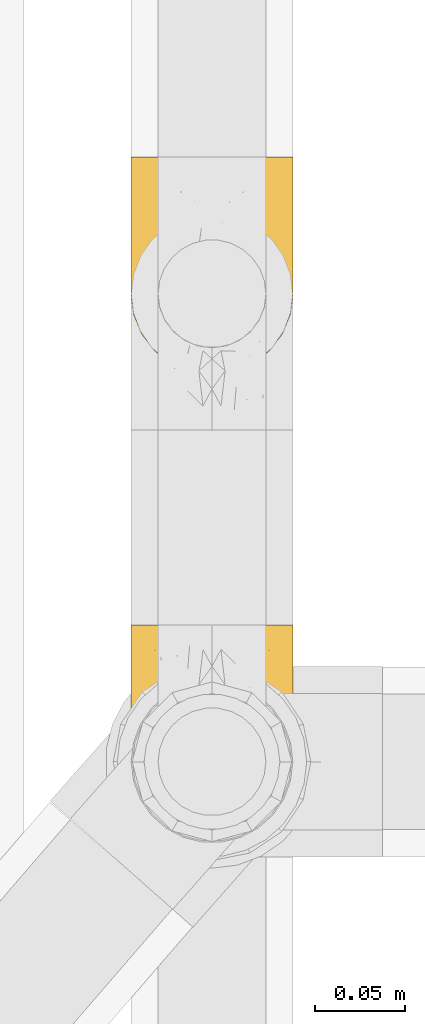
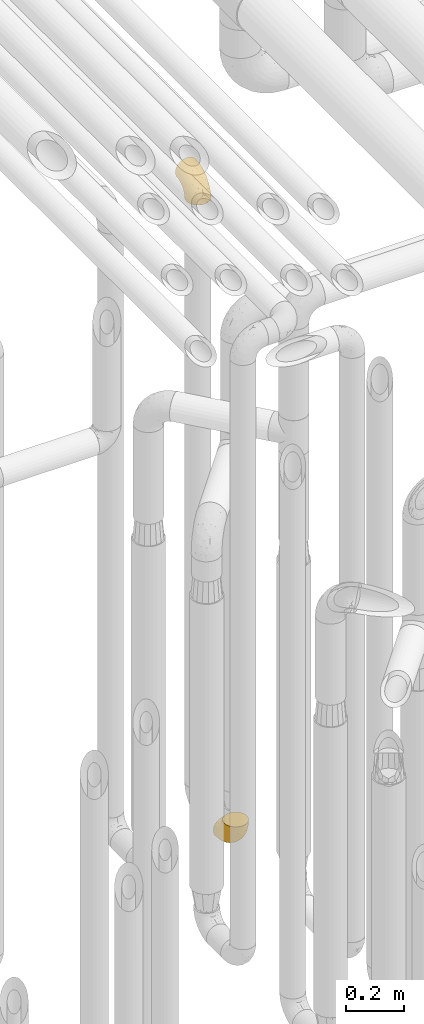
# One storey, part 231 of 827: 2 coverings.
"""IFC2X3 building model written with IfcOpenShell, lengths in millimetres."""

from ifc_helpers import new_model, entity, si_unit, converted_unit, derived_unit, direction, frame, origin, place, context, subcontext, project, spatial, faceted_brep, element, save


model = new_model("IFC2X3")

# Units and contexts
model_context = context("Model", 3, precision=0.01, world=origin(), true_north=direction((6.12303176911189e-17, 1.0)))
body_context = subcontext(model_context, "Body", "Model", "MODEL_VIEW")
ifc_project = project(units=[si_unit("LENGTHUNIT", "METRE", prefix="MILLI"), si_unit("AREAUNIT", "SQUARE_METRE"), si_unit("VOLUMEUNIT", "CUBIC_METRE"), converted_unit("PLANEANGLEUNIT", "DEGREE", entity("IfcRatioMeasure", 0.0174532925199433), si_unit("PLANEANGLEUNIT", "RADIAN"), dimensions=[0, 0, 0, 0, 0, 0, 0]), si_unit("MASSUNIT", "GRAM", prefix="KILO"), derived_unit("MASSDENSITYUNIT", [(si_unit("MASSUNIT", "GRAM", prefix="KILO"), 1), (si_unit("LENGTHUNIT", "METRE"), -3)]), derived_unit("MOMENTOFINERTIAUNIT", [(si_unit("LENGTHUNIT", "METRE"), 4)]), si_unit("TIMEUNIT", "SECOND"), si_unit("FREQUENCYUNIT", "HERTZ"), si_unit("THERMODYNAMICTEMPERATUREUNIT", "DEGREE_CELSIUS"), derived_unit("THERMALTRANSMITTANCEUNIT", [(si_unit("MASSUNIT", "GRAM", prefix="KILO"), 1), (si_unit("THERMODYNAMICTEMPERATUREUNIT", "KELVIN"), -1), (si_unit("TIMEUNIT", "SECOND"), -3)]), derived_unit("VOLUMETRICFLOWRATEUNIT", [(si_unit("LENGTHUNIT", "METRE"), 3), (si_unit("TIMEUNIT", "SECOND"), -1)]), derived_unit("MASSFLOWRATEUNIT", [(si_unit("MASSUNIT", "GRAM", prefix="KILO"), 1), (si_unit("TIMEUNIT", "SECOND"), -1)]), derived_unit("ROTATIONALFREQUENCYUNIT", [(si_unit("TIMEUNIT", "SECOND"), -1)]), si_unit("ELECTRICCURRENTUNIT", "AMPERE"), si_unit("ELECTRICVOLTAGEUNIT", "VOLT"), si_unit("POWERUNIT", "WATT"), si_unit("FORCEUNIT", "NEWTON", prefix="KILO"), si_unit("ILLUMINANCEUNIT", "LUX"), si_unit("LUMINOUSFLUXUNIT", "LUMEN"), si_unit("LUMINOUSINTENSITYUNIT", "CANDELA"), derived_unit("USERDEFINED", [(si_unit("MASSUNIT", "GRAM", prefix="KILO"), -1), (si_unit("LENGTHUNIT", "METRE"), -2), (si_unit("TIMEUNIT", "SECOND"), 3), (si_unit("LUMINOUSFLUXUNIT", "LUMEN"), 1)]), derived_unit("LINEARVELOCITYUNIT", [(si_unit("LENGTHUNIT", "METRE"), 1), (si_unit("TIMEUNIT", "SECOND"), -1)]), si_unit("PRESSUREUNIT", "PASCAL"), derived_unit("USERDEFINED", [(si_unit("LENGTHUNIT", "METRE"), -2), (si_unit("MASSUNIT", "GRAM", prefix="KILO"), 1), (si_unit("TIMEUNIT", "SECOND"), -2)]), derived_unit("LINEARFORCEUNIT", [(si_unit("MASSUNIT", "GRAM", prefix="KILO"), 1), (si_unit("LENGTHUNIT", "METRE"), 1), (si_unit("TIMEUNIT", "SECOND"), -2), (si_unit("LENGTHUNIT", "METRE"), -1)]), derived_unit("PLANARFORCEUNIT", [(si_unit("MASSUNIT", "GRAM", prefix="KILO"), 1), (si_unit("LENGTHUNIT", "METRE"), 1), (si_unit("TIMEUNIT", "SECOND"), -2), (si_unit("LENGTHUNIT", "METRE"), -2)])], contexts=[model_context])

# Site, building, storey
site_placement = place(None, origin())
site = spatial("IfcSite", under=ifc_project, at=site_placement, CompositionType="ELEMENT")
building_placement = place(site_placement, origin())
building = spatial("IfcBuilding", under=site, at=building_placement, CompositionType="ELEMENT")
storey_placement = place(building_placement, frame((0.0, 0.0, 28200.0)))
storey = spatial("IfcBuildingStorey", under=building, at=storey_placement, Name="08", CompositionType="ELEMENT", Elevation=28200.0)

# Coverings
covering_1_placement = place(storey_placement, frame((36928.29, 12932.9, 353.25)))
element("IfcCovering", 1, at=covering_1_placement, inside=storey, Name=":ADSK_", ObjectType=":ADSK_", PredefinedType="INSULATION", context=body_context, shape_type="Brep", body=[
    faceted_brep([(2.73, 36.69, 122.75), (6.07, 27.15, 122.75), (11.45, 18.59, 122.75), (18.6, 11.44, 122.75), (27.16, 6.06, 122.75), (36.7, 2.73, 122.75), (46.75, 1.6, 122.75), (56.8, 2.73, 122.75), (66.34, 6.07, 122.75), (74.9, 11.45, 122.75), (82.05, 18.6, 122.75), (87.43, 27.16, 122.75), (90.76, 36.7, 122.75), (91.9, 46.75, 122.75), (90.76, 56.8, 122.75), (87.42, 66.34, 122.75), (82.04, 74.9, 122.75), (74.89, 82.05, 122.75), (66.33, 87.43, 122.75), (56.79, 90.76, 122.75), (46.75, 91.9, 122.75), (36.69, 90.76, 122.75), (27.15, 87.42, 122.75), (18.59, 82.04, 122.75), (11.44, 74.89, 122.75), (6.06, 66.33, 122.75), (2.73, 56.79, 122.75), (1.6, 46.75, 122.75), (58.43, 122.75, 90.36), (69.32, 122.75, 85.85), (78.67, 122.75, 78.67), (85.85, 122.75, 69.32), (90.36, 122.75, 58.43), (91.9, 122.75, 46.75), (90.36, 122.75, 35.06), (85.85, 122.75, 24.17), (78.67, 122.75, 14.82), (69.32, 122.75, 7.64), (58.43, 122.75, 3.13), (46.75, 122.75, 1.6), (35.06, 122.75, 3.13), (24.17, 122.75, 7.64), (14.82, 122.75, 14.82), (7.64, 122.75, 24.17), (3.13, 122.75, 35.06), (1.6, 122.75, 46.75), (3.13, 122.75, 58.43), (7.64, 122.75, 69.32), (14.82, 122.75, 78.67), (24.17, 122.75, 85.85), (35.06, 122.75, 90.36), (46.75, 122.75, 91.9), (46.75, 24.73, 51.54), (38.29, 29.08, 47.17), (46.75, 38.13, 38.13), (46.75, 85.31, 7.52), (38.96, 93.59, 5.85), (46.75, 100.54, 5.11), (33.86, 63.54, 19.2), (31.42, 38.98, 38.98), (21.63, 50.71, 35.02), (30.84, 93.33, 8.21), (22.16, 75.2, 19.28), (20.56, 100.46, 12.19), (2.29, 41.6, 101.39), (7.18, 80.86, 34.43), (12.6, 94.87, 20.95), (14.0, 67.96, 30.74), (2.81, 52.16, 72.93), (6.65, 52.1, 56.64), (6.11, 36.74, 80.81), (16.62, 17.11, 93.43), (9.76, 23.24, 100.76), (12.46, 29.18, 74.27), (1.6, 52.53, 93.66), (1.6, 60.77, 81.33), (1.6, 69.01, 69.01), (2.46, 100.68, 40.87), (5.91, 103.79, 29.38), (36.97, 16.37, 67.05), (46.75, 7.52, 85.31), (33.09, 7.31, 93.68), (1.6, 93.66, 52.53), (1.6, 102.83, 50.71), (1.6, 112.01, 48.88), (25.62, 18.17, 72.77), (3.14, 71.97, 51.21), (23.92, 9.83, 101.18), (46.75, 5.11, 100.54), (13.58, 45.97, 48.74), (1.6, 48.88, 112.01), (1.6, 50.71, 102.83), (18.5, 22.83, 73.88), (46.75, 51.54, 24.73), (1.6, 81.33, 60.77), (4.96, 31.74, 103.08), (20.84, 32.48, 54.8), (46.75, 68.42, 16.13), (30.52, 25.33, 55.92), (46.75, 16.13, 68.42), (27.29, 92.29, 104.98), (36.89, 94.12, 108.58), (33.6, 100.97, 98.21), (2.54, 95.91, 61.56), (3.27, 107.9, 60.69), (16.85, 87.24, 100.0), (21.91, 95.46, 95.88), (13.5, 90.41, 90.81), (3.96, 74.17, 84.88), (3.52, 83.77, 73.29), (12.17, 76.72, 113.4), (18.93, 84.44, 109.8), (9.34, 76.42, 102.13), (3.12, 90.07, 67.29), (5.67, 99.69, 70.34), (2.51, 61.74, 95.15), (2.53, 58.16, 105.49), (8.35, 112.6, 71.5), (35.39, 110.45, 92.87), (46.75, 107.32, 96.03), (15.1, 108.48, 81.34), (5.27, 66.63, 107.44), (27.43, 115.23, 88.36), (24.89, 105.79, 90.43), (29.71, 89.6, 114.37), (5.07, 69.39, 98.41), (2.88, 66.99, 88.73), (9.69, 102.31, 76.89), (15.51, 99.54, 86.08), (2.27, 55.27, 112.64), (10.03, 82.03, 94.21), (46.75, 94.71, 112.22), (46.75, 96.03, 107.32), (8.83, 94.11, 79.95), (7.16, 84.21, 84.51), (46.75, 101.67, 101.67), (46.75, 112.22, 94.71), (78.39, 108.48, 81.34), (83.8, 102.31, 76.89), (77.97, 99.54, 86.08), (84.66, 94.11, 79.96), (58.1, 110.46, 92.87), (81.31, 76.74, 113.41), (91.9, 50.71, 102.83), (90.96, 58.17, 105.5), (91.22, 55.27, 112.64), (56.59, 94.12, 108.58), (66.18, 92.3, 104.98), (59.87, 100.98, 98.2), (88.42, 69.41, 98.4), (84.13, 76.44, 102.13), (88.22, 66.65, 107.44), (66.06, 115.24, 88.36), (91.9, 102.83, 50.71), (91.9, 112.01, 48.88), (83.44, 82.05, 94.22), (76.62, 87.25, 100.01), (85.14, 112.6, 71.5), (90.22, 107.9, 60.69), (91.9, 93.66, 52.53), (71.55, 95.48, 95.89), (63.77, 89.6, 114.37), (91.9, 60.77, 81.33), (91.9, 69.01, 69.01), (89.53, 74.17, 84.88), (91.9, 48.88, 112.01), (74.55, 84.45, 109.8), (90.95, 95.91, 61.56), (90.37, 90.07, 67.29), (91.9, 81.33, 60.77), (90.98, 61.75, 95.14), (89.97, 83.77, 73.29), (86.32, 84.21, 84.53), (91.9, 52.53, 93.66), (79.97, 90.42, 90.82), (90.61, 67.0, 88.73), (87.82, 99.69, 70.34), (68.6, 105.8, 90.43), (80.89, 94.87, 20.95), (86.31, 80.86, 34.43), (79.49, 67.95, 30.74), (71.33, 75.17, 19.29), (71.88, 50.65, 35.07), (90.35, 71.97, 51.21), (86.85, 52.08, 56.67), (72.67, 32.46, 54.85), (62.08, 38.98, 38.98), (87.58, 103.79, 29.38), (91.03, 100.68, 40.87), (59.62, 63.54, 19.2), (62.65, 93.32, 8.21), (54.53, 93.59, 5.85), (72.93, 100.44, 12.19), (90.68, 52.17, 72.93), (87.39, 36.75, 80.83), (91.2, 41.61, 101.39), (60.41, 7.31, 93.69), (76.88, 17.12, 93.43), (56.53, 16.37, 67.04), (83.74, 23.26, 100.76), (67.88, 18.17, 72.78), (62.99, 25.33, 55.93), (69.58, 9.84, 101.18), (81.04, 29.19, 74.27), (75.0, 22.84, 73.89), (88.53, 31.75, 103.09), (79.93, 45.96, 48.78), (55.21, 29.07, 47.19)], [[[0, 1, 2, 3, 4, 5, 6, 7, 8, 9, 10, 11, 12, 13, 14, 15, 16, 17, 18, 19, 20, 21, 22, 23, 24, 25, 26, 27]], [[28, 29, 30, 31, 32, 33, 34, 35, 36, 37, 38, 39, 40, 41, 42, 43, 44, 45, 46, 47, 48, 49, 50, 51]], [[52, 53, 54]], [[55, 56, 57]], [[58, 59, 60]], [[61, 62, 63]], [[27, 64, 0]], [[65, 66, 67]], [[41, 40, 61]], [[68, 69, 70]], [[66, 43, 42]], [[63, 42, 41]], [[71, 72, 73]], [[72, 2, 1]], [[68, 74, 75, 76]], [[45, 44, 77]], [[43, 78, 44]], [[79, 80, 81]], [[77, 82, 83, 84, 45]], [[79, 81, 85]], [[71, 2, 72]], [[65, 86, 77]], [[4, 81, 5]], [[66, 65, 78]], [[4, 3, 87]], [[81, 88, 5]], [[63, 66, 42]], [[68, 70, 64]], [[67, 60, 89]], [[71, 3, 2]], [[64, 27, 90, 91, 74]], [[92, 71, 73]], [[40, 57, 56]], [[59, 93, 54]], [[86, 76, 94, 82]], [[1, 0, 95]], [[58, 62, 61]], [[60, 96, 89]], [[85, 81, 87]], [[56, 97, 58]], [[65, 67, 69]], [[87, 81, 4]], [[67, 89, 69]], [[61, 63, 41]], [[95, 72, 1]], [[73, 72, 70]], [[69, 73, 70]], [[73, 89, 96]], [[3, 71, 87]], [[85, 87, 71]], [[58, 61, 56]], [[59, 58, 93]], [[76, 86, 68]], [[69, 89, 73]], [[68, 86, 69]], [[65, 69, 86]], [[68, 64, 74]], [[95, 64, 70]], [[98, 79, 85]], [[79, 52, 99, 80]], [[66, 62, 67]], [[62, 58, 60]], [[62, 60, 67]], [[59, 98, 96]], [[59, 96, 60]], [[96, 85, 92]], [[88, 81, 80]], [[88, 6, 5]], [[66, 63, 62]], [[64, 95, 0]], [[72, 95, 70]], [[77, 44, 78]], [[86, 82, 77]], [[40, 39, 57]], [[96, 98, 85]], [[40, 56, 61]], [[66, 78, 43]], [[77, 78, 65]], [[79, 98, 53]], [[96, 92, 73]], [[85, 71, 92]], [[97, 56, 55]], [[97, 93, 58]], [[53, 98, 59]], [[54, 53, 59]], [[79, 53, 52]], [[100, 101, 102]], [[46, 45, 84, 83]], [[103, 104, 82]], [[82, 104, 83]], [[105, 106, 107]], [[108, 109, 76]], [[110, 111, 112]], [[103, 113, 114]], [[115, 74, 116]], [[48, 47, 117]], [[118, 102, 119]], [[49, 48, 120]], [[74, 91, 116]], [[116, 121, 115]], [[49, 122, 50]], [[123, 106, 102]], [[124, 111, 22]], [[125, 126, 115]], [[23, 22, 111]], [[24, 110, 121]], [[120, 127, 128]], [[90, 26, 129]], [[27, 26, 90]], [[121, 125, 115]], [[24, 121, 25]], [[130, 105, 107]], [[129, 25, 116]], [[21, 20, 131]], [[120, 123, 122]], [[112, 105, 130]], [[50, 118, 51]], [[21, 124, 22]], [[101, 131, 132]], [[117, 120, 48]], [[24, 23, 110]], [[127, 114, 133]], [[75, 108, 76]], [[107, 134, 130]], [[133, 114, 113]], [[129, 116, 91]], [[25, 121, 116]], [[121, 112, 125]], [[75, 74, 115]], [[101, 135, 102]], [[131, 101, 21]], [[101, 100, 124]], [[128, 127, 133]], [[119, 136, 51, 118]], [[104, 47, 46]], [[83, 104, 46]], [[117, 104, 114]], [[101, 124, 21]], [[111, 124, 100]], [[102, 118, 123]], [[133, 134, 107]], [[111, 110, 23]], [[114, 104, 103]], [[94, 76, 109]], [[121, 110, 112]], [[122, 118, 50]], [[134, 109, 108]], [[133, 107, 128]], [[112, 108, 125]], [[126, 125, 108]], [[108, 75, 126]], [[75, 115, 126]], [[109, 134, 133]], [[130, 108, 112]], [[108, 130, 134]], [[105, 112, 111]], [[111, 100, 105]], [[106, 105, 100]], [[102, 106, 100]], [[128, 106, 123]], [[90, 129, 91]], [[25, 129, 26]], [[104, 117, 47]], [[117, 114, 127]], [[82, 94, 103]], [[113, 94, 109]], [[94, 113, 103]], [[133, 113, 109]], [[106, 128, 107]], [[123, 120, 128]], [[120, 122, 49]], [[118, 122, 123]], [[135, 101, 132]], [[135, 119, 102]], [[117, 127, 120]], [[30, 29, 137]], [[138, 139, 140]], [[51, 136, 119, 141]], [[142, 17, 16]], [[143, 144, 145]], [[146, 147, 148]], [[149, 150, 151]], [[152, 29, 28]], [[33, 32, 153, 154]], [[150, 155, 156]], [[157, 31, 30]], [[153, 158, 159]], [[29, 152, 137]], [[148, 141, 119]], [[156, 160, 147]], [[148, 135, 146]], [[137, 138, 157]], [[19, 161, 146]], [[162, 163, 164]], [[14, 13, 165]], [[153, 32, 158]], [[147, 161, 166]], [[18, 17, 166]], [[167, 168, 169]], [[166, 150, 156]], [[151, 150, 142]], [[151, 170, 149]], [[151, 16, 15]], [[171, 140, 172]], [[165, 143, 145]], [[173, 170, 144]], [[142, 166, 17]], [[19, 131, 20]], [[144, 170, 151]], [[18, 161, 19]], [[173, 144, 143]], [[140, 139, 174]], [[171, 164, 163]], [[164, 172, 155]], [[151, 15, 144]], [[145, 15, 14]], [[173, 162, 170]], [[149, 175, 164]], [[19, 146, 131]], [[132, 131, 146]], [[160, 148, 147]], [[159, 158, 167]], [[135, 132, 146]], [[158, 32, 31]], [[157, 158, 31]], [[167, 158, 176]], [[166, 161, 18]], [[146, 161, 147]], [[148, 177, 141]], [[171, 168, 140]], [[171, 163, 169]], [[151, 142, 16]], [[166, 142, 150]], [[152, 141, 177]], [[51, 141, 28]], [[138, 140, 176]], [[172, 140, 174]], [[175, 149, 170]], [[164, 150, 149]], [[170, 162, 175]], [[162, 164, 175]], [[155, 172, 174]], [[171, 172, 164]], [[155, 174, 156]], [[164, 155, 150]], [[160, 156, 174]], [[147, 166, 156]], [[139, 160, 174]], [[148, 160, 177]], [[15, 145, 144]], [[165, 145, 14]], [[137, 157, 30]], [[158, 157, 176]], [[168, 167, 176]], [[169, 159, 167]], [[140, 168, 176]], [[169, 168, 171]], [[137, 177, 139]], [[160, 139, 177]], [[141, 152, 28]], [[137, 152, 177]], [[148, 119, 135]], [[157, 138, 176]], [[139, 138, 137]], [[178, 179, 180]], [[181, 180, 182]], [[179, 183, 184]], [[185, 186, 182]], [[187, 188, 179]], [[188, 33, 154, 153, 159]], [[181, 189, 190]], [[35, 34, 187]], [[191, 38, 190]], [[192, 178, 181]], [[179, 184, 180]], [[192, 190, 37]], [[37, 190, 38]], [[36, 35, 178]], [[54, 93, 186]], [[35, 187, 178]], [[193, 194, 184]], [[195, 173, 143, 165, 13]], [[195, 193, 173]], [[193, 163, 162, 173]], [[13, 12, 195]], [[8, 7, 196]], [[9, 197, 10]], [[198, 80, 99, 52]], [[196, 7, 88]], [[197, 199, 10]], [[182, 189, 181]], [[200, 198, 201]], [[200, 196, 198]], [[9, 8, 202]], [[194, 199, 203]], [[192, 37, 36]], [[80, 196, 88]], [[183, 159, 169, 163]], [[188, 34, 33]], [[202, 200, 197]], [[185, 203, 204]], [[202, 8, 196]], [[10, 199, 11]], [[12, 11, 205]], [[38, 191, 57]], [[189, 97, 191]], [[203, 199, 197]], [[205, 199, 194]], [[204, 203, 197]], [[184, 203, 206]], [[200, 202, 196]], [[197, 9, 202]], [[207, 54, 186]], [[97, 55, 191]], [[194, 203, 184]], [[183, 163, 193]], [[184, 206, 180]], [[183, 193, 184]], [[205, 195, 12]], [[193, 195, 194]], [[80, 198, 196]], [[207, 186, 201]], [[182, 180, 206]], [[181, 178, 180]], [[185, 182, 206]], [[182, 186, 189]], [[203, 185, 206]], [[185, 200, 201]], [[7, 6, 88]], [[178, 192, 36]], [[190, 192, 181]], [[199, 205, 11]], [[195, 205, 194]], [[159, 183, 188]], [[179, 188, 183]], [[57, 191, 55]], [[57, 39, 38]], [[189, 191, 190]], [[188, 187, 34]], [[178, 187, 179]], [[186, 93, 189]], [[197, 200, 204]], [[185, 204, 200]], [[189, 93, 97]], [[207, 198, 52]], [[185, 201, 186]], [[198, 207, 201]], [[54, 207, 52]]]),
])
covering_2_placement = place(storey_placement, frame((36928.29, 13193.46, 2922.4)))
element("IfcCovering", 2, at=covering_2_placement, inside=storey, Name=":ADSK_", ObjectType=":ADSK_", PredefinedType="INSULATION", context=body_context, shape_type="Brep", body=[
    faceted_brep([(2.73, 122.75, 87.65), (6.07, 122.75, 97.19), (11.45, 122.75, 105.75), (18.6, 122.75, 112.9), (27.16, 122.75, 118.28), (36.7, 122.75, 121.61), (46.75, 122.75, 122.75), (56.8, 122.75, 121.61), (66.34, 122.75, 118.27), (74.9, 122.75, 112.89), (82.05, 122.75, 105.74), (87.43, 122.75, 97.18), (90.76, 122.75, 87.64), (91.9, 122.75, 77.6), (90.76, 122.75, 67.54), (87.42, 122.75, 58.0), (82.04, 122.75, 49.44), (74.89, 122.75, 42.29), (66.33, 122.75, 36.91), (56.79, 122.75, 33.58), (46.75, 122.75, 32.45), (36.69, 122.75, 33.58), (27.15, 122.75, 36.92), (18.59, 122.75, 42.3), (11.44, 122.75, 49.45), (6.06, 122.75, 58.01), (2.73, 122.75, 67.55), (1.6, 122.75, 77.6), (58.43, 90.36, 1.6), (69.32, 85.85, 1.6), (78.67, 78.67, 1.6), (85.85, 69.32, 1.6), (90.36, 58.43, 1.6), (91.9, 46.75, 1.6), (90.36, 35.06, 1.6), (85.85, 24.17, 1.6), (78.67, 14.82, 1.6), (69.32, 7.64, 1.6), (58.43, 3.13, 1.6), (46.75, 1.6, 1.6), (35.06, 3.13, 1.6), (24.17, 7.64, 1.6), (14.82, 14.82, 1.6), (7.64, 24.17, 1.6), (3.13, 35.06, 1.6), (1.6, 46.75, 1.6), (3.13, 58.43, 1.6), (7.64, 69.32, 1.6), (14.82, 78.67, 1.6), (24.17, 85.85, 1.6), (35.06, 90.36, 1.6), (46.75, 91.9, 1.6), (46.75, 51.54, 99.61), (38.29, 47.17, 95.26), (46.75, 38.13, 86.21), (46.75, 7.52, 39.03), (38.96, 5.85, 30.75), (46.75, 5.11, 23.8), (33.86, 19.2, 60.8), (31.42, 38.98, 85.37), (21.63, 35.02, 73.64), (30.84, 8.21, 31.01), (22.16, 19.28, 49.14), (20.56, 12.19, 23.88), (2.29, 101.39, 82.74), (7.18, 34.43, 43.48), (12.6, 20.95, 29.47), (14.0, 30.74, 56.38), (2.81, 72.93, 72.18), (6.65, 56.64, 72.24), (6.11, 80.81, 87.6), (16.62, 93.43, 107.24), (9.76, 100.76, 101.1), (12.46, 74.27, 95.16), (1.6, 93.66, 71.81), (1.6, 81.33, 63.57), (1.6, 69.01, 55.34), (2.46, 40.87, 23.66), (5.91, 29.38, 20.55), (36.97, 67.05, 107.97), (46.75, 85.31, 116.82), (33.09, 93.68, 117.03), (1.6, 52.53, 30.68), (1.6, 50.71, 21.51), (1.6, 48.88, 12.33), (25.62, 72.77, 106.17), (3.14, 51.21, 52.37), (23.92, 101.18, 114.51), (46.75, 100.54, 119.23), (13.58, 48.74, 78.37), (1.6, 112.01, 75.46), (1.6, 102.83, 73.63), (18.5, 73.88, 101.51), (46.75, 24.73, 72.81), (1.6, 60.77, 43.01), (4.96, 103.08, 92.6), (20.84, 54.8, 91.86), (46.75, 16.13, 55.92), (30.52, 55.92, 99.01), (46.75, 68.42, 108.21), (27.29, 104.98, 32.05), (36.89, 108.58, 30.22), (33.6, 98.21, 23.37), (2.54, 61.56, 28.43), (3.27, 60.69, 16.44), (16.85, 100.0, 37.1), (21.91, 95.88, 28.88), (13.5, 90.81, 33.93), (3.96, 84.88, 50.17), (3.52, 73.29, 40.57), (12.17, 113.4, 47.62), (18.93, 109.8, 39.9), (9.34, 102.13, 47.92), (3.12, 67.29, 34.27), (5.67, 70.34, 24.65), (2.51, 95.15, 62.6), (2.53, 105.49, 66.18), (8.35, 71.5, 11.74), (35.39, 92.87, 13.89), (46.75, 96.03, 17.02), (15.1, 81.34, 15.86), (5.27, 107.44, 57.71), (27.43, 88.36, 9.11), (24.89, 90.43, 18.55), (29.71, 114.37, 34.74), (5.07, 98.41, 54.95), (2.88, 88.73, 57.35), (9.69, 76.89, 22.03), (15.51, 86.08, 24.8), (2.27, 112.64, 69.07), (10.03, 94.21, 42.31), (46.75, 112.22, 29.63), (46.75, 107.32, 28.31), (8.83, 79.95, 30.23), (7.16, 84.51, 40.13), (46.75, 101.67, 22.67), (46.75, 94.71, 12.12), (78.39, 81.34, 15.86), (83.8, 76.89, 22.03), (77.97, 86.08, 24.8), (84.66, 79.96, 30.23), (58.1, 92.87, 13.88), (81.31, 113.41, 47.61), (91.9, 102.83, 73.63), (90.96, 105.5, 66.17), (91.22, 112.64, 69.07), (56.59, 108.58, 30.22), (66.18, 104.98, 32.04), (59.87, 98.2, 23.36), (88.42, 98.4, 54.93), (84.13, 102.13, 47.91), (88.22, 107.44, 57.69), (66.06, 88.36, 9.1), (91.9, 50.71, 21.51), (91.9, 48.88, 12.33), (83.44, 94.22, 42.29), (76.62, 100.01, 37.09), (85.14, 71.5, 11.74), (90.22, 60.69, 16.44), (91.9, 52.53, 30.68), (71.55, 95.89, 28.86), (63.77, 114.37, 34.74), (91.9, 81.33, 63.57), (91.9, 69.01, 55.34), (89.53, 84.88, 50.17), (91.9, 112.01, 75.46), (74.55, 109.8, 39.89), (90.95, 61.56, 28.43), (90.37, 67.29, 34.27), (91.9, 60.77, 43.01), (90.98, 95.14, 62.59), (89.97, 73.29, 40.57), (86.32, 84.53, 40.13), (91.9, 93.66, 71.81), (79.97, 90.82, 33.92), (90.61, 88.73, 57.34), (87.82, 70.34, 24.65), (68.6, 90.43, 18.54), (80.89, 20.95, 29.47), (86.31, 34.43, 43.48), (79.49, 30.74, 56.4), (71.33, 19.29, 49.17), (71.88, 35.07, 73.69), (90.35, 51.21, 52.37), (86.85, 56.67, 72.26), (72.67, 54.85, 91.88), (62.08, 38.98, 85.36), (87.58, 29.38, 20.55), (91.03, 40.87, 23.66), (59.62, 19.2, 60.8), (62.65, 8.21, 31.02), (54.53, 5.85, 30.75), (72.93, 12.19, 23.9), (90.68, 72.93, 72.17), (87.39, 80.83, 87.59), (91.2, 101.39, 82.74), (60.41, 93.69, 117.03), (76.88, 93.43, 107.23), (56.53, 67.04, 107.97), (83.74, 100.76, 101.08), (67.88, 72.78, 106.17), (62.99, 55.93, 99.01), (69.58, 101.18, 114.5), (81.04, 74.27, 95.15), (75.0, 73.89, 101.5), (88.53, 103.09, 92.59), (79.93, 48.78, 78.38), (55.21, 47.19, 95.27)], [[[0, 1, 2, 3, 4, 5, 6, 7, 8, 9, 10, 11, 12, 13, 14, 15, 16, 17, 18, 19, 20, 21, 22, 23, 24, 25, 26, 27]], [[28, 29, 30, 31, 32, 33, 34, 35, 36, 37, 38, 39, 40, 41, 42, 43, 44, 45, 46, 47, 48, 49, 50, 51]], [[52, 53, 54]], [[55, 56, 57]], [[58, 59, 60]], [[61, 62, 63]], [[27, 64, 0]], [[65, 66, 67]], [[41, 40, 61]], [[68, 69, 70]], [[66, 43, 42]], [[63, 42, 41]], [[71, 72, 73]], [[72, 2, 1]], [[68, 74, 75, 76]], [[45, 44, 77]], [[43, 78, 44]], [[79, 80, 81]], [[77, 82, 83, 84, 45]], [[79, 81, 85]], [[71, 2, 72]], [[65, 86, 77]], [[4, 81, 5]], [[66, 65, 78]], [[4, 3, 87]], [[81, 88, 5]], [[63, 66, 42]], [[68, 70, 64]], [[67, 60, 89]], [[71, 3, 2]], [[64, 27, 90, 91, 74]], [[92, 71, 73]], [[40, 57, 56]], [[59, 93, 54]], [[86, 76, 94, 82]], [[1, 0, 95]], [[58, 62, 61]], [[60, 96, 89]], [[85, 81, 87]], [[56, 97, 58]], [[65, 67, 69]], [[87, 81, 4]], [[67, 89, 69]], [[61, 63, 41]], [[95, 72, 1]], [[73, 72, 70]], [[69, 73, 70]], [[73, 89, 96]], [[3, 71, 87]], [[85, 87, 71]], [[58, 61, 56]], [[59, 58, 93]], [[76, 86, 68]], [[69, 89, 73]], [[68, 86, 69]], [[65, 69, 86]], [[68, 64, 74]], [[95, 64, 70]], [[98, 79, 85]], [[79, 52, 99, 80]], [[66, 62, 67]], [[62, 58, 60]], [[62, 60, 67]], [[59, 98, 96]], [[59, 96, 60]], [[96, 85, 92]], [[88, 81, 80]], [[88, 6, 5]], [[66, 63, 62]], [[64, 95, 0]], [[72, 95, 70]], [[77, 44, 78]], [[86, 82, 77]], [[40, 39, 57]], [[96, 98, 85]], [[40, 56, 61]], [[66, 78, 43]], [[77, 78, 65]], [[79, 98, 53]], [[96, 92, 73]], [[85, 71, 92]], [[97, 56, 55]], [[97, 93, 58]], [[53, 98, 59]], [[54, 53, 59]], [[79, 53, 52]], [[100, 101, 102]], [[46, 45, 84, 83]], [[103, 104, 82]], [[82, 104, 83]], [[105, 106, 107]], [[108, 109, 76]], [[110, 111, 112]], [[103, 113, 114]], [[115, 74, 116]], [[48, 47, 117]], [[118, 102, 119]], [[49, 48, 120]], [[74, 91, 116]], [[116, 121, 115]], [[49, 122, 50]], [[123, 106, 102]], [[124, 111, 22]], [[125, 126, 115]], [[23, 22, 111]], [[24, 110, 121]], [[120, 127, 128]], [[90, 26, 129]], [[27, 26, 90]], [[121, 125, 115]], [[24, 121, 25]], [[130, 105, 107]], [[129, 25, 116]], [[21, 20, 131]], [[120, 123, 122]], [[112, 105, 130]], [[50, 118, 51]], [[21, 124, 22]], [[101, 131, 132]], [[117, 120, 48]], [[24, 23, 110]], [[127, 114, 133]], [[75, 108, 76]], [[107, 134, 130]], [[133, 114, 113]], [[129, 116, 91]], [[25, 121, 116]], [[121, 112, 125]], [[75, 74, 115]], [[101, 135, 102]], [[131, 101, 21]], [[101, 100, 124]], [[128, 127, 133]], [[119, 136, 51, 118]], [[104, 47, 46]], [[83, 104, 46]], [[117, 104, 114]], [[101, 124, 21]], [[111, 124, 100]], [[102, 118, 123]], [[133, 134, 107]], [[111, 110, 23]], [[114, 104, 103]], [[94, 76, 109]], [[121, 110, 112]], [[122, 118, 50]], [[134, 109, 108]], [[133, 107, 128]], [[112, 108, 125]], [[126, 125, 108]], [[108, 75, 126]], [[75, 115, 126]], [[109, 134, 133]], [[130, 108, 112]], [[108, 130, 134]], [[105, 112, 111]], [[111, 100, 105]], [[106, 105, 100]], [[102, 106, 100]], [[128, 106, 123]], [[90, 129, 91]], [[25, 129, 26]], [[104, 117, 47]], [[117, 114, 127]], [[82, 94, 103]], [[113, 94, 109]], [[94, 113, 103]], [[133, 113, 109]], [[106, 128, 107]], [[123, 120, 128]], [[120, 122, 49]], [[118, 122, 123]], [[135, 101, 132]], [[135, 119, 102]], [[117, 127, 120]], [[30, 29, 137]], [[138, 139, 140]], [[51, 136, 119, 141]], [[142, 17, 16]], [[143, 144, 145]], [[146, 147, 148]], [[149, 150, 151]], [[152, 29, 28]], [[33, 32, 153, 154]], [[150, 155, 156]], [[157, 31, 30]], [[153, 158, 159]], [[29, 152, 137]], [[148, 141, 119]], [[156, 160, 147]], [[148, 135, 146]], [[137, 138, 157]], [[19, 161, 146]], [[162, 163, 164]], [[14, 13, 165]], [[153, 32, 158]], [[147, 161, 166]], [[18, 17, 166]], [[167, 168, 169]], [[166, 150, 156]], [[151, 150, 142]], [[151, 170, 149]], [[151, 16, 15]], [[171, 140, 172]], [[165, 143, 145]], [[173, 170, 144]], [[142, 166, 17]], [[19, 131, 20]], [[144, 170, 151]], [[18, 161, 19]], [[173, 144, 143]], [[140, 139, 174]], [[171, 164, 163]], [[164, 172, 155]], [[151, 15, 144]], [[145, 15, 14]], [[173, 162, 170]], [[149, 175, 164]], [[19, 146, 131]], [[132, 131, 146]], [[160, 148, 147]], [[159, 158, 167]], [[135, 132, 146]], [[158, 32, 31]], [[157, 158, 31]], [[167, 158, 176]], [[166, 161, 18]], [[146, 161, 147]], [[148, 177, 141]], [[171, 168, 140]], [[171, 163, 169]], [[151, 142, 16]], [[166, 142, 150]], [[152, 141, 177]], [[51, 141, 28]], [[138, 140, 176]], [[172, 140, 174]], [[175, 149, 170]], [[164, 150, 149]], [[170, 162, 175]], [[162, 164, 175]], [[155, 172, 174]], [[171, 172, 164]], [[155, 174, 156]], [[164, 155, 150]], [[160, 156, 174]], [[147, 166, 156]], [[139, 160, 174]], [[148, 160, 177]], [[15, 145, 144]], [[165, 145, 14]], [[137, 157, 30]], [[158, 157, 176]], [[168, 167, 176]], [[169, 159, 167]], [[140, 168, 176]], [[169, 168, 171]], [[137, 177, 139]], [[160, 139, 177]], [[141, 152, 28]], [[137, 152, 177]], [[148, 119, 135]], [[157, 138, 176]], [[139, 138, 137]], [[178, 179, 180]], [[181, 180, 182]], [[179, 183, 184]], [[185, 186, 182]], [[187, 188, 179]], [[188, 33, 154, 153, 159]], [[181, 189, 190]], [[35, 34, 187]], [[191, 38, 190]], [[192, 178, 181]], [[179, 184, 180]], [[192, 190, 37]], [[37, 190, 38]], [[36, 35, 178]], [[54, 93, 186]], [[35, 187, 178]], [[193, 194, 184]], [[195, 173, 143, 165, 13]], [[195, 193, 173]], [[193, 163, 162, 173]], [[13, 12, 195]], [[8, 7, 196]], [[9, 197, 10]], [[198, 80, 99, 52]], [[196, 7, 88]], [[197, 199, 10]], [[182, 189, 181]], [[200, 198, 201]], [[200, 196, 198]], [[9, 8, 202]], [[194, 199, 203]], [[192, 37, 36]], [[80, 196, 88]], [[183, 159, 169, 163]], [[188, 34, 33]], [[202, 200, 197]], [[185, 203, 204]], [[202, 8, 196]], [[10, 199, 11]], [[12, 11, 205]], [[38, 191, 57]], [[189, 97, 191]], [[203, 199, 197]], [[205, 199, 194]], [[204, 203, 197]], [[184, 203, 206]], [[200, 202, 196]], [[197, 9, 202]], [[207, 54, 186]], [[97, 55, 191]], [[194, 203, 184]], [[183, 163, 193]], [[184, 206, 180]], [[183, 193, 184]], [[205, 195, 12]], [[193, 195, 194]], [[80, 198, 196]], [[207, 186, 201]], [[182, 180, 206]], [[181, 178, 180]], [[185, 182, 206]], [[182, 186, 189]], [[203, 185, 206]], [[185, 200, 201]], [[7, 6, 88]], [[178, 192, 36]], [[190, 192, 181]], [[199, 205, 11]], [[195, 205, 194]], [[159, 183, 188]], [[179, 188, 183]], [[57, 191, 55]], [[57, 39, 38]], [[189, 191, 190]], [[188, 187, 34]], [[178, 187, 179]], [[186, 93, 189]], [[197, 200, 204]], [[185, 204, 200]], [[189, 93, 97]], [[207, 198, 52]], [[185, 201, 186]], [[198, 207, 201]], [[54, 207, 52]]]),
])

save(model, "model.ifc")
